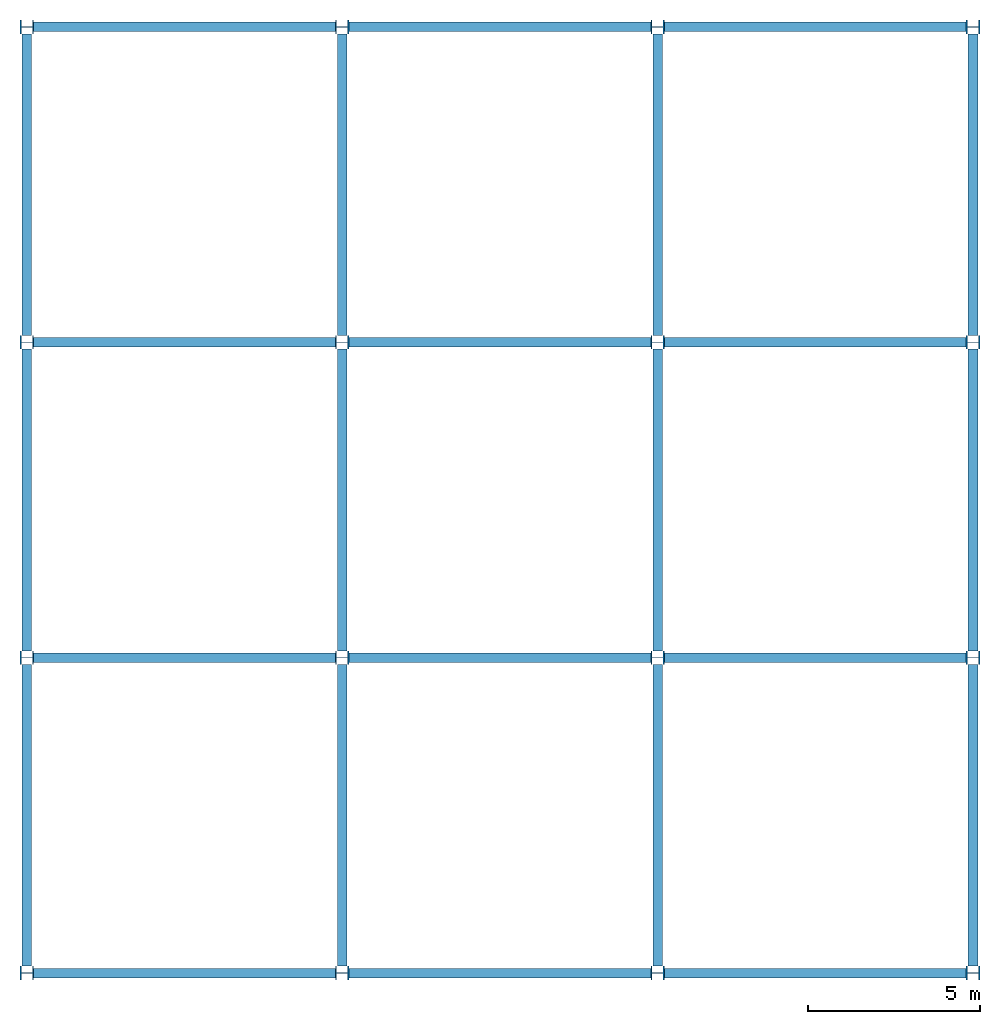
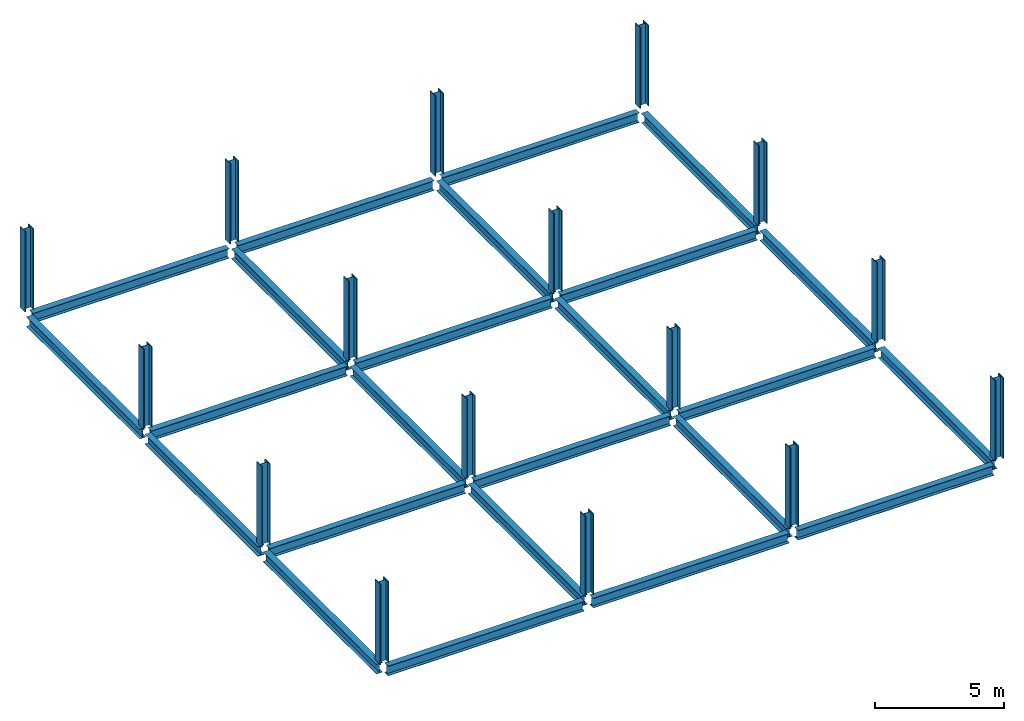
# One storey: 24 beams, 16 columns.
"""IFC2X3 building model written with IfcOpenShell, lengths in inches."""

from ifc_helpers import new_model, entity, si_unit, converted_unit, derived_unit, frame, origin_with_axes, origin_2d_with_axis, place, context, project, spatial, i_section, transform_2d, derived_profile, extrude, material, element, save


model = new_model("IFC2X3")

# Units and contexts
model_context = context("Model", 3, world=origin_with_axes())
ifc_project = project(units=[converted_unit("LENGTHUNIT", "INCH", entity("IfcLengthMeasure", 25.4), si_unit("LENGTHUNIT", "METRE", prefix="MILLI"), dimensions=[1, 0, 0, 0, 0, 0, 0]), converted_unit("AREAUNIT", "SQUARE INCH", entity("IfcAreaMeasure", 645.16), si_unit("AREAUNIT", "SQUARE_METRE", prefix="MICRO"), dimensions=[2, 0, 0, 0, 0, 0, 0]), converted_unit("VOLUMEUNIT", "CUBIC INCH", entity("IfcVolumeMeasure", 16387.064), si_unit("VOLUMEUNIT", "CUBIC_METRE", prefix="NANO"), dimensions=[3, 0, 0, 0, 0, 0, 0]), derived_unit("SECTIONMODULUSUNIT", [(converted_unit("LENGTHUNIT", "INCH", entity("IfcLengthMeasure", 25.4), si_unit("LENGTHUNIT", "METRE", prefix="MILLI"), dimensions=[1, 0, 0, 0, 0, 0, 0]), 3)]), derived_unit("MOMENTOFINERTIAUNIT", [(converted_unit("LENGTHUNIT", "INCH", entity("IfcLengthMeasure", 25.4), si_unit("LENGTHUNIT", "METRE", prefix="MILLI"), dimensions=[1, 0, 0, 0, 0, 0, 0]), 4)]), si_unit("PLANEANGLEUNIT", "RADIAN"), si_unit("TIMEUNIT", "SECOND"), converted_unit("FORCEUNIT", "LBF", entity("IfcForceMeasure", 4.448222), si_unit("FORCEUNIT", "NEWTON"), dimensions=[1, 1, -2, 0, 0, 0, 0]), derived_unit("TORQUEUNIT", [(converted_unit("LENGTHUNIT", "INCH", entity("IfcLengthMeasure", 25.4), si_unit("LENGTHUNIT", "METRE", prefix="MILLI"), dimensions=[1, 0, 0, 0, 0, 0, 0]), 1), (converted_unit("FORCEUNIT", "LBF", entity("IfcForceMeasure", 4.448222), si_unit("FORCEUNIT", "NEWTON"), dimensions=[1, 1, -2, 0, 0, 0, 0]), 1)]), converted_unit("PRESSUREUNIT", "PSI", entity("IfcPressureMeasure", 6894.7579), si_unit("PRESSUREUNIT", "PASCAL"), dimensions=[-1, 1, -2, 0, 0, 0, 0]), derived_unit("LINEARFORCEUNIT", [(converted_unit("LENGTHUNIT", "INCH", entity("IfcLengthMeasure", 25.4), si_unit("LENGTHUNIT", "METRE", prefix="MILLI"), dimensions=[1, 0, 0, 0, 0, 0, 0]), -1), (converted_unit("FORCEUNIT", "LBF", entity("IfcForceMeasure", 4.448222), si_unit("FORCEUNIT", "NEWTON"), dimensions=[1, 1, -2, 0, 0, 0, 0]), 1)]), derived_unit("PLANARFORCEUNIT", [(converted_unit("LENGTHUNIT", "INCH", entity("IfcLengthMeasure", 25.4), si_unit("LENGTHUNIT", "METRE", prefix="MILLI"), dimensions=[1, 0, 0, 0, 0, 0, 0]), -2), (converted_unit("FORCEUNIT", "LBF", entity("IfcForceMeasure", 4.448222), si_unit("FORCEUNIT", "NEWTON"), dimensions=[1, 1, -2, 0, 0, 0, 0]), 1)]), derived_unit("LINEARMOMENTUNIT", [(converted_unit("FORCEUNIT", "LBF", entity("IfcForceMeasure", 4.448222), si_unit("FORCEUNIT", "NEWTON"), dimensions=[1, 1, -2, 0, 0, 0, 0]), 1), (converted_unit("LENGTHUNIT", "INCH", entity("IfcLengthMeasure", 25.4), si_unit("LENGTHUNIT", "METRE", prefix="MILLI"), dimensions=[1, 0, 0, 0, 0, 0, 0]), 1), (converted_unit("LENGTHUNIT", "INCH", entity("IfcLengthMeasure", 25.4), si_unit("LENGTHUNIT", "METRE", prefix="MILLI"), dimensions=[1, 0, 0, 0, 0, 0, 0]), -1)]), derived_unit("SHEARMODULUSUNIT", [(converted_unit("LENGTHUNIT", "INCH", entity("IfcLengthMeasure", 25.4), si_unit("LENGTHUNIT", "METRE", prefix="MILLI"), dimensions=[1, 0, 0, 0, 0, 0, 0]), -2), (converted_unit("FORCEUNIT", "LBF", entity("IfcForceMeasure", 4.448222), si_unit("FORCEUNIT", "NEWTON"), dimensions=[1, 1, -2, 0, 0, 0, 0]), 1)]), derived_unit("MODULUSOFELASTICITYUNIT", [(converted_unit("LENGTHUNIT", "INCH", entity("IfcLengthMeasure", 25.4), si_unit("LENGTHUNIT", "METRE", prefix="MILLI"), dimensions=[1, 0, 0, 0, 0, 0, 0]), -2), (converted_unit("FORCEUNIT", "LBF", entity("IfcForceMeasure", 4.448222), si_unit("FORCEUNIT", "NEWTON"), dimensions=[1, 1, -2, 0, 0, 0, 0]), 1)]), converted_unit("THERMODYNAMICTEMPERATUREUNIT", "FAHRENHEIT", entity("IfcThermodynamicTemperatureMeasure", 0.55555556), si_unit("THERMODYNAMICTEMPERATUREUNIT", "KELVIN"), dimensions=[0, 0, 0, 0, 1, 0, 0]), derived_unit("THERMALEXPANSIONCOEFFICIENTUNIT", [(converted_unit("THERMODYNAMICTEMPERATUREUNIT", "FAHRENHEIT", entity("IfcThermodynamicTemperatureMeasure", 0.55555556), si_unit("THERMODYNAMICTEMPERATUREUNIT", "KELVIN"), dimensions=[0, 0, 0, 0, 1, 0, 0]), -1)])], contexts=[model_context])

# Site, building, storey
site = spatial("IfcSite", under=ifc_project, CompositionType="ELEMENT")
building = spatial("IfcBuilding", under=site, Name="Default Building", CompositionType="ELEMENT")
storey = spatial("IfcBuildingStorey", under=building, Name="LEVEL 2", CompositionType="ELEMENT", Elevation=192.0)

# Columns
ifc_material = material(Name="A992Fy50")
for number, where, z_axis, x_axis, name in (
    (1, (0.0, 0.0, 192.0), (0.0, 0.0, 1.0), (0.0, -1.0, 0.0), "17"),
    (2, (0.0, 360.0, 192.0), (0.0, 0.0, 1.0), (0.0, -1.0, 0.0), "18"),
    (3, (0.0, 720.0, 192.0), (0.0, 0.0, 1.0), (0.0, -1.0, 0.0), "19"),
    (4, (0.0, 1080.0, 192.0), (0.0, 0.0, 1.0), (0.0, -1.0, 0.0), "20"),
    (5, (360.0, 0.0, 192.0), (0.0, 0.0, 1.0), (0.0, -1.0, 0.0), "21"),
    (6, (360.0, 360.0, 192.0), (0.0, 0.0, 1.0), (0.0, -1.0, 0.0), "22"),
    (7, (360.0, 720.0, 192.0), (0.0, 0.0, 1.0), (0.0, -1.0, 0.0), "23"),
    (8, (360.0, 1080.0, 192.0), (0.0, 0.0, 1.0), (0.0, -1.0, 0.0), "24"),
    (9, (720.0, 0.0, 192.0), (0.0, 0.0, 1.0), (0.0, -1.0, 0.0), "25"),
    (10, (720.0, 360.0, 192.0), (0.0, 0.0, 1.0), (0.0, -1.0, 0.0), "26"),
    (11, (720.0, 720.0, 192.0), (0.0, 0.0, 1.0), (0.0, -1.0, 0.0), "27"),
    (12, (720.0, 1080.0, 192.0), (0.0, 0.0, 1.0), (0.0, -1.0, 0.0), "28"),
    (13, (1080.0, 0.0, 192.0), (0.0, 0.0, 1.0), (0.0, -1.0, 0.0), "29"),
    (14, (1080.0, 360.0, 192.0), (0.0, 0.0, 1.0), (0.0, -1.0, 0.0), "30"),
    (15, (1080.0, 720.0, 192.0), (0.0, 0.0, 1.0), (0.0, -1.0, 0.0), "31"),
    (16, (1080.0, 1080.0, 192.0), (0.0, 0.0, 1.0), (0.0, -1.0, 0.0), "32"),
):
    element("IfcColumn", number, at=place(None, frame(where, z_axis=z_axis, x_axis=x_axis)), inside=storey, material=ifc_material, Name=name, context=model_context, shape_type="SweptSolid", body=[
        extrude(i_section(OverallWidth=15.7, OverallDepth=15.5, WebThickness=0.89, FlangeThickness=1.44, at=origin_2d_with_axis()), origin_with_axes(), (0.0, 0.0, 1.0), 149.6),
    ])

# Beams
for number, where, z_axis, x_axis, name in (
    (17, (0.0, 7.85, 192.0), (0.0, 1.0, 0.0), (-1.0, 0.0, 0.0), "97"),
    (18, (0.0, 367.85, 192.0), (0.0, 1.0, 0.0), (-1.0, 0.0, 0.0), "98"),
    (19, (0.0, 727.85, 192.0), (0.0, 1.0, 0.0), (-1.0, 0.0, 0.0), "99"),
    (20, (360.0, 7.85, 192.0), (0.0, 1.0, 0.0), (-1.0, 0.0, 0.0), "100"),
    (21, (360.0, 367.85, 192.0), (0.0, 1.0, 0.0), (-1.0, 0.0, 0.0), "101"),
    (22, (360.0, 727.85, 192.0), (0.0, 1.0, 0.0), (-1.0, 0.0, 0.0), "102"),
    (23, (720.0, 7.85, 192.0), (0.0, 1.0, 0.0), (-1.0, 0.0, 0.0), "103"),
    (24, (720.0, 367.85, 192.0), (0.0, 1.0, 0.0), (-1.0, 0.0, 0.0), "104"),
    (25, (720.0, 727.85, 192.0), (0.0, 1.0, 0.0), (-1.0, 0.0, 0.0), "105"),
    (26, (1080.0, 7.85, 192.0), (0.0, 1.0, 0.0), (-1.0, 0.0, 0.0), "106"),
    (27, (1080.0, 367.85, 192.0), (0.0, 1.0, 0.0), (-1.0, 0.0, 0.0), "107"),
    (28, (1080.0, 727.85, 192.0), (0.0, 1.0, 0.0), (-1.0, 0.0, 0.0), "108"),
):
    element("IfcBeam", number, at=place(None, frame(where, z_axis=z_axis, x_axis=x_axis)), inside=storey, material=ifc_material, Name=name, context=model_context, shape_type="SweptSolid", body=[
        extrude(derived_profile(i_section(OverallWidth=11.0, OverallDepth=18.2, WebThickness=0.425, FlangeThickness=0.68, at=origin_2d_with_axis()), transform_2d((0.0, -9.1000004))), origin_with_axes(), (0.0, 0.0, 1.0), 344.3),
    ])
for number, where, z_axis, x_axis, name in (
    (29, (7.75, 0.0, 192.0), (1.0, 0.0, 0.0), (0.0, 1.0, 0.0), "109"),
    (30, (367.75, 0.0, 192.0), (1.0, 0.0, 0.0), (0.0, 1.0, 0.0), "110"),
    (31, (727.75, 0.0, 192.0), (1.0, 0.0, 0.0), (0.0, 1.0, 0.0), "111"),
    (32, (7.75, 360.0, 192.0), (1.0, 0.0, 0.0), (0.0, 1.0, 0.0), "112"),
    (33, (367.75, 360.0, 192.0), (1.0, 0.0, 0.0), (0.0, 1.0, 0.0), "113"),
    (34, (727.75, 360.0, 192.0), (1.0, 0.0, 0.0), (0.0, 1.0, 0.0), "114"),
    (35, (7.75, 720.0, 192.0), (1.0, 0.0, 0.0), (0.0, 1.0, 0.0), "115"),
    (36, (367.75, 720.0, 192.0), (1.0, 0.0, 0.0), (0.0, 1.0, 0.0), "116"),
    (37, (727.75, 720.0, 192.0), (1.0, 0.0, 0.0), (0.0, 1.0, 0.0), "117"),
    (38, (7.75, 1080.0, 192.0), (1.0, 0.0, 0.0), (0.0, 1.0, 0.0), "118"),
    (39, (367.75, 1080.0, 192.0), (1.0, 0.0, 0.0), (0.0, 1.0, 0.0), "119"),
    (40, (727.75, 1080.0, 192.0), (1.0, 0.0, 0.0), (0.0, 1.0, 0.0), "120"),
):
    element("IfcBeam", number, at=place(None, frame(where, z_axis=z_axis, x_axis=x_axis)), inside=storey, material=ifc_material, Name=name, context=model_context, shape_type="SweptSolid", body=[
        extrude(derived_profile(i_section(OverallWidth=11.0, OverallDepth=18.2, WebThickness=0.425, FlangeThickness=0.68, at=origin_2d_with_axis()), transform_2d((0.0, -9.1000004))), origin_with_axes(), (0.0, 0.0, 1.0), 344.5),
    ])

save(model, "model.ifc")
